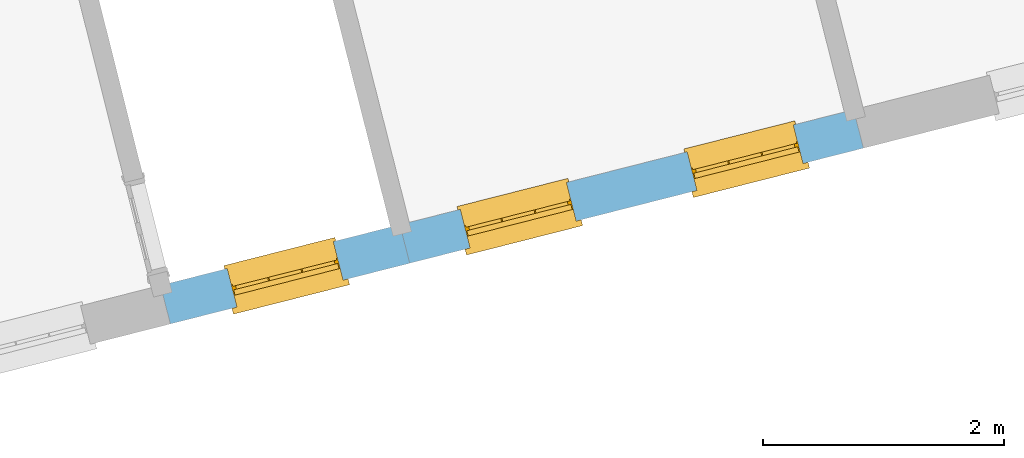
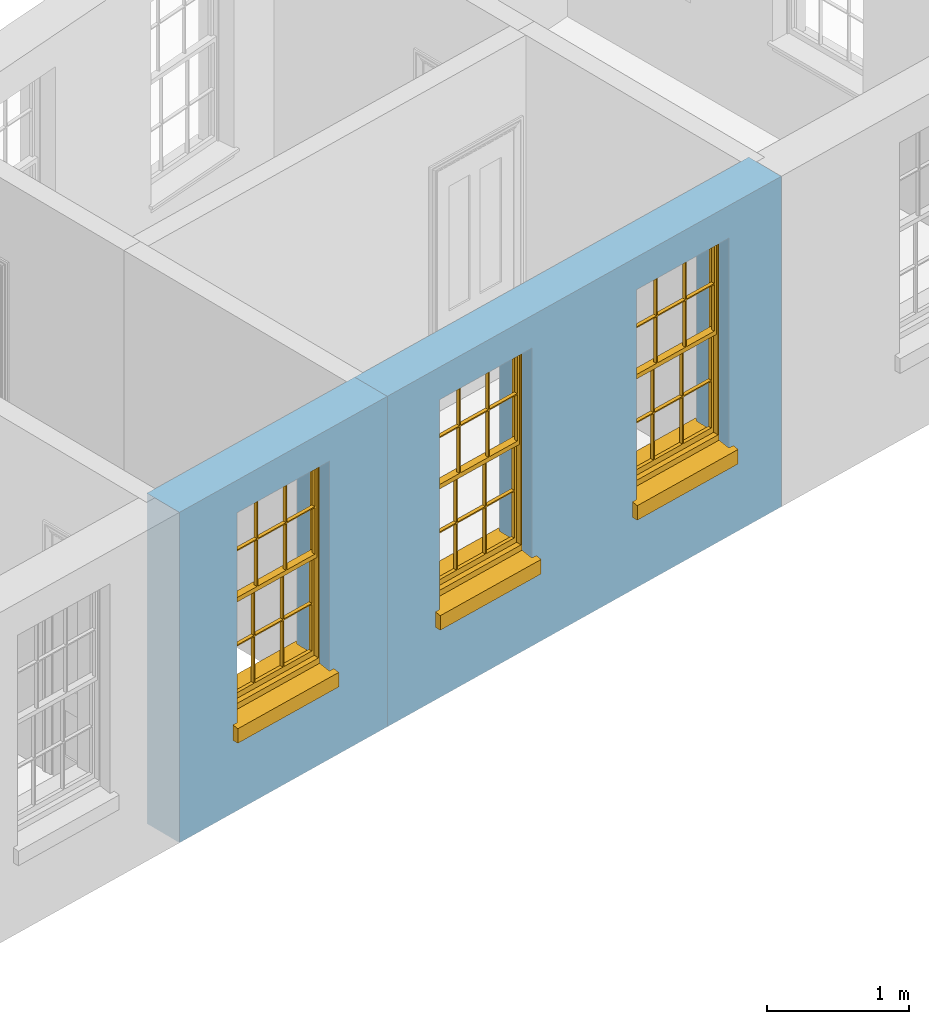
# One storey, part 5 of 11: 3 windows, 3 openings, plus 2 elements that do not belong to this part.
"""IFC2X3 building model written with IfcOpenShell, lengths in metres."""

import ifcopenshell
import ifcopenshell.guid

model = None  # the IFC model being written
_history = None  # IfcOwnerHistory: only IFC2X3 demands one
_inside = {}  # id of a spatial element -> (the spatial element, [elements in it])
_under = {}  # id of a project, library or spatial element -> (it, [spatial elements below it])
_declared = {}  # id of a project -> (the project, [libraries it declares])
_typed = {}  # id of a type object -> (the type object, [elements of that type])
_made_of = {}  # id of a material, layer set ... -> (it, [elements and type objects made of it])


def new_model(schema):
    """Start an empty IFC model of exactly this schema.

    Asked for "IFC4X3", IfcOpenShell would pick the latest addendum, in which some entities
    have other attributes; the version numbers below select the first issue.
    IFC2X3 requires an IfcOwnerHistory on every rooted entity: one is made here for all.
    """
    global model, _history
    if schema == "IFC4X3":
        model = ifcopenshell.file(schema_version=(4, 3, 0, 0))
    else:
        model = ifcopenshell.file(schema=schema)
    _inside.clear()
    _under.clear()
    _declared.clear()
    _typed.clear()
    _made_of.clear()
    _history = None
    if model.schema == "IFC2X3":
        org = make("IfcOrganization", Name="unknown")
        user = make(
            "IfcPersonAndOrganization",
            ThePerson=make("IfcPerson", FamilyName="unknown"),
            TheOrganization=org,
        )
        app = make(
            "IfcApplication",
            ApplicationDeveloper=org,
            Version="unknown",
            ApplicationFullName="unknown",
            ApplicationIdentifier="unknown",
        )
        _history = make(
            "IfcOwnerHistory",
            OwningUser=user,
            OwningApplication=app,
            ChangeAction="ADDED",
            CreationDate=0,
        )
    return model


def make(cls, **values):
    """One entity of the class cls with the attributes given. An attribute that is None is left unset."""
    return model.create_entity(
        cls, **{name: value for name, value in values.items() if value is not None}
    )


def rooted(cls, **values):
    """An entity with a GlobalId (a new one), such as an element, a storey or a relation."""
    return make(cls, GlobalId=ifcopenshell.guid.new(), OwnerHistory=_history, **values)


def si_unit(unit_type, name, prefix=None):
    """IfcSIUnit, for example si_unit("LENGTHUNIT", "METRE", prefix="MILLI")."""
    return make("IfcSIUnit", UnitType=unit_type, Prefix=prefix, Name=name)


def assignment(units):
    """IfcUnitAssignment: the units of a project."""
    return None if units is None else make("IfcUnitAssignment", Units=units)


def point(xyz):
    """IfcCartesianPoint."""
    return None if xyz is None else make("IfcCartesianPoint", Coordinates=xyz)


def direction(xyz):
    """IfcDirection."""
    return None if xyz is None else make("IfcDirection", DirectionRatios=xyz)


def frame(location, z_axis=None, x_axis=None):
    """IfcAxis2Placement3D, a coordinate frame: its origin and axes. An axis left out is left unset."""
    return make(
        "IfcAxis2Placement3D",
        Location=point(location),
        Axis=direction(z_axis),
        RefDirection=direction(x_axis),
    )


def origin():
    """The frame at (0, 0, 0) with its axes left unset."""
    return frame((0.0, 0.0, 0.0))


def place(relative_to, where):
    """IfcLocalPlacement: puts the frame where relative to a parent placement (None: the world)."""
    return make(
        "IfcLocalPlacement", PlacementRelTo=relative_to, RelativePlacement=where
    )


def context(
    kind, dimensions, precision=None, world=None, true_north=None, identifier=None
):
    """IfcGeometricRepresentationContext, for example the 3D "Model" context."""
    return make(
        "IfcGeometricRepresentationContext",
        ContextIdentifier=identifier,
        ContextType=kind,
        CoordinateSpaceDimension=dimensions,
        Precision=precision,
        WorldCoordinateSystem=world,
        TrueNorth=true_north,
    )


def subcontext(parent, identifier, kind, view, scale=None):
    """IfcGeometricRepresentationSubContext, for example "Body" below "Model"."""
    return make(
        "IfcGeometricRepresentationSubContext",
        ContextIdentifier=identifier,
        ContextType=kind,
        ParentContext=parent,
        TargetScale=scale,
        TargetView=view,
    )


def project(units=None, contexts=None):
    """IfcProject with its units and contexts."""
    return rooted(
        "IfcProject",
        Name="project",
        RepresentationContexts=contexts,
        UnitsInContext=assignment(units),
    )


def spatial(cls, under=None, at=None, **own):
    """A site, building, storey or space (cls), placed at a placement, below another one or the project."""
    s = rooted(cls, ObjectPlacement=at, **own)
    if under is not None:
        _under.setdefault(under.id(), (under, []))[1].append(s)
    return s


def polyline(points):
    """IfcPolyline through the points."""
    return make("IfcPolyline", Points=[point(p) for p in points])


def outline(outer, holes=None, kind="AREA"):
    """IfcArbitraryClosedProfileDef: a profile drawn as a closed curve; with holes, ...WithVoids."""
    if holes is None:
        return make("IfcArbitraryClosedProfileDef", ProfileType=kind, OuterCurve=outer)
    return make(
        "IfcArbitraryProfileDefWithVoids",
        ProfileType=kind,
        OuterCurve=outer,
        InnerCurves=holes,
    )


def extrude(swept, where, along, depth):
    """IfcExtrudedAreaSolid: the profile swept, set in the frame where, extruded along a direction by depth."""
    return make(
        "IfcExtrudedAreaSolid",
        SweptArea=swept,
        Position=where,
        ExtrudedDirection=direction(along),
        Depth=depth,
    )


def faces_of(points, faces, orient=None, outer=None):
    """IfcFace entities. A face is a list of loops; a loop is a list of indices into points, from 0.

    orient and outer hold one flag for each loop. By default every Orientation is true, the
    first loop of a face is its IfcFaceOuterBound and the others are IfcFaceBound.
    """
    made = []
    for i, loops in enumerate(faces):
        bounds = []
        for j, loop in enumerate(loops):
            is_outer = j == 0 if outer is None else outer[i][j]
            bounds.append(
                make(
                    "IfcFaceOuterBound" if is_outer else "IfcFaceBound",
                    Bound=make("IfcPolyLoop", Polygon=[points[k] for k in loop]),
                    Orientation=True if orient is None else orient[i][j],
                )
            )
        made.append(make("IfcFace", Bounds=bounds))
    return made


def faceted_brep(points, faces, orient=None, outer=None, voids=None):
    """IfcFacetedBrep: a solid bounded by flat faces; with voids (closed shells), ...WithVoids."""
    shared = [point(p) for p in points]
    hull = make("IfcClosedShell", CfsFaces=faces_of(shared, faces, orient, outer))
    if voids is None:
        return make("IfcFacetedBrep", Outer=hull)
    return make(
        "IfcFacetedBrepWithVoids",
        Outer=hull,
        Voids=[
            make(cls, CfsFaces=faces_of(shared, fs, o, b)) for cls, fs, o, b in voids
        ],
    )


def shape(context_of_items, identifier, shape_type, items):
    """IfcShapeRepresentation: the items that make up one representation, for example the "Body"."""
    return make(
        "IfcShapeRepresentation",
        ContextOfItems=context_of_items,
        RepresentationIdentifier=identifier,
        RepresentationType=shape_type,
        Items=items,
    )


def material(Name=None, Category=None):
    """IfcMaterial."""
    return make("IfcMaterial", Name=Name, Category=Category)


def layer(
    of_material, thickness, ventilated=None, Name=None, Category=None, Priority=None
):
    """IfcMaterialLayer: one layer of a wall or slab, of a material (None: an air gap)."""
    return make(
        "IfcMaterialLayer",
        Material=of_material,
        LayerThickness=thickness,
        IsVentilated=ventilated,
        Name=Name,
        Category=Category,
        Priority=Priority,
    )


def layer_set(layers, Name=None):
    """IfcMaterialLayerSet."""
    return make("IfcMaterialLayerSet", MaterialLayers=layers, LayerSetName=Name)


def layer_usage(for_layer_set, set_direction, sense, offset, extent=None):
    """IfcMaterialLayerSetUsage: how a layer set lies in its element."""
    return make(
        "IfcMaterialLayerSetUsage",
        ForLayerSet=for_layer_set,
        LayerSetDirection=set_direction,
        DirectionSense=sense,
        OffsetFromReferenceLine=offset,
        ReferenceExtent=extent,
    )


def made_of(thing, what):
    """Note that an element or type object is made of a material, layer set ...; save() writes the relation."""
    if what is not None:
        _made_of.setdefault(what.id(), (what, []))[1].append(thing)
    return thing


def element(
    cls,
    number,
    at=None,
    inside=None,
    cuts=None,
    type_object=None,
    material=None,
    context=None,
    identifier="Body",
    shape_type=None,
    held_by="IfcProductDefinitionShape",
    body=None,
    shapes=None,
    **own,
):
    """One element of the class cls, such as IfcWall. Its Tag is "e" and its number.

    at: its placement. inside: the storey or other place that contains it. cuts: it is an
    opening in that element (IfcRelVoidsElement). A single representation is given by context,
    identifier, shape_type and body (its items); several are given by shapes. held_by: the class
    of the entity that holds the representations. save() writes the other relations.
    """
    e = rooted(cls, Tag="e%d" % number, ObjectPlacement=at, **own)
    if body is not None:
        shapes = [shape(context, identifier, shape_type, body)]
    if shapes is not None:
        e.Representation = make(held_by, Representations=shapes)
    if inside is not None:
        _inside.setdefault(inside.id(), (inside, []))[1].append(e)
    if cuts is not None:
        rooted(
            "IfcRelVoidsElement", RelatingBuildingElement=cuts, RelatedOpeningElement=e
        )
    if type_object is not None:
        _typed.setdefault(type_object.id(), (type_object, []))[1].append(e)
    return made_of(e, material)


def fill(opening, filler):
    """IfcRelFillsElement: the door or window that sits in an opening."""
    return rooted(
        "IfcRelFillsElement",
        RelatingOpeningElement=opening,
        RelatedBuildingElement=filler,
    )


def aggregate(whole, parts):
    """IfcRelAggregates: a whole, such as a stair, and the parts it consists of."""
    return rooted("IfcRelAggregates", RelatingObject=whole, RelatedObjects=parts)


def save(model, path):
    """Write the relations noted so far, then the file.

    IfcRelAggregates (storeys below a building ...), IfcRelContainedInSpatialStructure (elements
    in a storey), IfcRelDefinesByType, IfcRelAssociatesMaterial and IfcRelDeclares: one each for
    every whole, place, type object, material and project.
    """
    for whole, parts in _under.values():
        aggregate(whole, parts)
    for where, things in _inside.values():
        rooted(
            "IfcRelContainedInSpatialStructure",
            RelatedElements=things,
            RelatingStructure=where,
        )
    for kind, things in _typed.values():
        rooted("IfcRelDefinesByType", RelatedObjects=things, RelatingType=kind)
    for what, things in _made_of.values():
        rooted("IfcRelAssociatesMaterial", RelatedObjects=things, RelatingMaterial=what)
    for by, libraries in _declared.values():
        rooted("IfcRelDeclares", RelatingContext=by, RelatedDefinitions=libraries)
    model.write(path)


model = new_model("IFC2X3")

# Units and contexts
model_context = context("Model", 3, world=origin())
body_context = subcontext(model_context, "Body", "Model", "MODEL_VIEW")
ifc_project = project(units=[si_unit("PLANEANGLEUNIT", "RADIAN"), si_unit("MASSUNIT", "GRAM", prefix="KILO"), si_unit("FORCEUNIT", "NEWTON", prefix="KILO"), si_unit("LENGTHUNIT", "METRE")], contexts=[model_context])

# Site, building, storey
site_placement = place(None, origin())
site = spatial("IfcSite", under=ifc_project, at=site_placement, CompositionType="ELEMENT")
building_placement = place(None, origin())
building = spatial("IfcBuilding", under=site, at=building_placement, Name="Building plot-13", CompositionType="ELEMENT")
storey_placement = place(None, frame((0.0, 0.0, 6.7)))
storey = spatial("IfcBuildingStorey", under=building, at=storey_placement, Name="Floor 1", CompositionType="ELEMENT", Elevation=6.7)

# Wall, opening, window
ifc_material = material(Name="Masonry")
ifc_layer = layer(ifc_material, 0.33, ventilated=False)
ifc_layer_set = layer_set([ifc_layer], Name="My Wall")
ifc_layer_usage = layer_usage(ifc_layer_set, "AXIS2", "NEGATIVE", 0.08)
wall_1_placement = place(storey_placement, origin())
wall_1 = element("IfcWallStandardCase", 1, at=wall_1_placement, inside=storey, material=ifc_layer_usage, Name="exterior", context=body_context, shape_type="SweptSolid", body=[
    extrude(outline(polyline([(71.1697724625834, 45.0137628318924), (71.2509007169492, 44.6938906600119), (73.2374229095042, 45.1977265416814), (73.1562946551384, 45.5175987135619), (71.1697724625834, 45.0137628318924)])), origin(), (0.0, 0.0, 1.0), 2.85),
])
opening_1_placement = place(storey_placement, frame((0.0, 0.0, 0.75)))
opening_1 = element("IfcOpeningElement", 2, at=opening_1_placement, cuts=wall_1, Name="Opening", ObjectType="Opening", context=body_context, shape_type="SweptSolid", body=[
    extrude(outline(polyline([(71.8031259398763, 44.8339499470999), (72.6851976865771, 45.0576672545935), (72.6040694322113, 45.377539426474), (71.7219976855105, 45.1538221189804), (71.8031259398763, 44.8339499470999)])), origin(), (0.0, 0.0, 1.0), 1.82),
])
window_1_placement = place(storey_placement, frame((71.7416651411143, 45.0762773500396, 0.75), z_axis=(0.0, 0.0, 1.0), x_axis=(0.882071746700788, 0.223717307493636, 0.0)))
window_1 = element("IfcWindow", 3, at=window_1_placement, inside=storey, Name="circulation outside window", OverallHeight=1.82, OverallWidth=0.91, context=body_context, shape_type="Brep", held_by="IfcProductRepresentation", body=[
    faceted_brep([(0.033125, -0.105, 0.975209), (0.01, -0.105, 0.975209), (0.033125, -0.105, 1.376042), (0.876875, -0.105, 0.975209), (0.876875, -0.105, 1.376042), (0.9, -0.105, 0.975209), (0.876875, -0.105, 1.386042), (0.876875, -0.105, 1.786875), (0.9, -0.105, 1.81), (0.033125, -0.105, 1.786875), (0.033125, -0.105, 1.386042), (0.01, -0.105, 1.81), (0.876875, -0.135, 1.376042), (0.876875, -0.135, 0.975209), (0.9, -0.135, 0.937083), (0.033125, -0.135, 1.786875), (0.01, -0.135, 1.81), (0.033125, -0.135, 1.386042), (0.01, -0.135, 0.937083), (0.033125, -0.135, 0.975209), (0.033125, -0.135, 1.376042), (0.876875, -0.135, 1.786875), (0.876875, -0.135, 1.386042), (0.9, -0.135, 1.81), (0.033125, -0.105, 0.937083), (0.01, -0.105, 0.937083), (0.033125, -0.105, 0.53625), (0.876875, -0.105, 0.937083), (0.876875, -0.105, 0.53625), (0.9, -0.105, 0.937083), (0.876875, -0.105, 0.52625), (0.876875, -0.105, 0.125417), (0.9, -0.105, 0.077167), (0.033125, -0.105, 0.125417), (0.033125, -0.105, 0.52625), (0.01, -0.105, 0.077167), (-0.0425, -0.25, 0.01), (-0.0425, -0.3, 0.001667), (0.0, -0.25, 0.01), (0.9525, -0.25, 0.01), (0.91, -0.25, 0.01), (0.9525, -0.3, 0.001667), (-0.02, 0.08, 0.077167), (0.0, 0.08, 0.077167), (-0.02, 0.11, 0.077167), (0.0, -0.06, 0.077167), (0.01, -0.06, 0.077167), (0.91, -0.06, 0.077167), (0.91, 0.08, 0.077167), (0.9, -0.06, 0.077167), (0.93, 0.08, 0.077167), (0.93, 0.11, 0.077167), (0.01, -0.075, 0.975209), (0.9, -0.075, 0.975209), (0.876875, -0.075, 0.125417), (0.876875, -0.075, 0.52625), (0.9, -0.075, 0.077167), (0.876875, -0.075, 0.53625), (0.876875, -0.075, 0.937083), (0.033125, -0.075, 0.125417), (0.01, -0.075, 0.077167), (0.033125, -0.075, 0.52625), (0.033125, -0.075, 0.937083), (0.033125, -0.075, 0.53625), (-0.02, 0.08, 0.052167), (-0.02, 0.11, 0.052167), (0.93, 0.11, 0.052167), (0.93, 0.08, 0.052167), (0.91, 0.08, 0.052167), (0.0, 0.08, 0.052167), (0.91, -0.15, 0.026667), (0.0, -0.15, 0.026667), (-0.0425, -0.3, -0.123333), (0.9525, -0.3, -0.123333), (-0.0425, -0.25, -0.123333), (0.9525, -0.25, -0.123333), (0.01, -0.06, 1.81), (0.9, -0.06, 1.81), (0.0, -0.06, 1.82), (0.91, -0.06, 1.82), (0.01, -0.15, 0.077167), (0.9, -0.15, 0.077167), (0.592292, -0.105, 0.125417), (0.592292, -0.075, 0.125417), (0.317708, -0.075, 0.125417), (0.317708, -0.105, 0.125417), (0.592292, -0.105, 0.53625), (0.317708, -0.105, 0.53625), (0.317708, -0.105, 0.52625), (0.592292, -0.105, 0.52625), (0.592292, -0.075, 0.53625), (0.317708, -0.075, 0.53625), (0.592292, -0.135, 1.386042), (0.592292, -0.105, 1.386042), (0.317708, -0.105, 1.386042), (0.317708, -0.135, 1.386042), (0.317708, -0.135, 1.376042), (0.592292, -0.135, 1.376042), (0.317708, -0.105, 1.376042), (0.592292, -0.105, 1.376042), (0.602292, -0.135, 1.376042), (0.592292, -0.135, 0.975209), (0.602292, -0.135, 0.975209), (0.602292, -0.105, 0.975209), (0.592292, -0.105, 0.975209), (0.602292, -0.105, 1.376042), (0.602292, -0.075, 0.53625), (0.602292, -0.105, 0.53625), (0.317708, -0.075, 0.52625), (0.307708, -0.075, 0.125417), (0.307708, -0.075, 0.52625), (0.602292, -0.075, 0.52625), (0.602292, -0.075, 0.125417), (0.592292, -0.075, 0.52625), (0.307708, -0.075, 0.53625), (0.317708, -0.075, 0.937083), (0.307708, -0.075, 0.937083), (0.602292, -0.075, 0.937083), (0.592292, -0.075, 0.937083), (0.307708, -0.105, 0.52625), (0.307708, -0.105, 0.125417), (0.307708, -0.105, 0.53625), (0.307708, -0.105, 0.937083), (0.592292, -0.105, 0.937083), (0.317708, -0.105, 0.937083), (0.602292, -0.105, 0.937083), (0.602292, -0.105, 0.52625), (0.602292, -0.105, 0.125417), (0.307708, -0.135, 1.386042), (0.307708, -0.135, 1.376042), (0.307708, -0.135, 0.975209), (0.317708, -0.135, 0.975209), (0.317708, -0.135, 1.786875), (0.307708, -0.135, 1.786875), (0.602292, -0.135, 1.786875), (0.592292, -0.135, 1.786875), (0.602292, -0.135, 1.386042), (0.602292, -0.105, 1.386042), (0.307708, -0.105, 1.386042), (0.307708, -0.105, 1.786875), (0.317708, -0.105, 1.786875), (0.592292, -0.105, 1.786875), (0.602292, -0.105, 1.786875), (0.307708, -0.105, 1.376042), (0.317708, -0.105, 0.975209), (0.307708, -0.105, 0.975209), (0.91, -0.15, 1.82), (0.9, -0.15, 1.81), (0.01, -0.15, 1.81), (0.0, -0.15, 1.82), (0.91, -0.25, 0.0), (0.0, -0.25, 0.0), (0.91, 0.08, 0.0), (0.0, 0.08, 0.0)], [[[0, 1, 2]], [[3, 4, 5]], [[6, 7, 8]], [[9, 10, 11]], [[12, 13, 14]], [[15, 16, 17]], [[18, 19, 20]], [[21, 22, 23]], [[24, 25, 26]], [[27, 28, 29]], [[30, 31, 32]], [[33, 34, 35]], [[14, 27, 29]], [[25, 24, 18]], [[36, 37, 38]], [[39, 40, 41]], [[42, 43, 44]], [[45, 46, 43]], [[47, 48, 49]], [[50, 51, 48]], [[1, 0, 52]], [[5, 53, 3]], [[54, 55, 56]], [[57, 58, 53]], [[59, 60, 61]], [[62, 63, 52]], [[48, 43, 46, 49]], [[51, 44, 43, 48]], [[64, 42, 44, 65]], [[65, 44, 51, 66]], [[66, 51, 50, 67]], [[65, 66, 68, 69]], [[60, 56, 49, 46]], [[70, 71, 38, 40]], [[37, 41, 40, 38]], [[37, 72, 73, 41]], [[74, 75, 73, 72]], [[8, 11, 76, 77]], [[76, 78, 79, 77]], [[32, 35, 80, 81]], [[81, 80, 71, 70]], [[82, 83, 84, 85]], [[86, 87, 88, 89]], [[86, 90, 91, 87]], [[92, 93, 94, 95]], [[92, 95, 96, 97]], [[96, 98, 99, 97]], [[100, 97, 101, 102]], [[103, 104, 99, 105]], [[97, 99, 104, 101]], [[102, 103, 105, 100]], [[28, 57, 106, 107]], [[108, 84, 109, 110]], [[111, 112, 83, 113]], [[114, 110, 61, 63]], [[90, 113, 108, 91]], [[115, 91, 114, 116]], [[117, 106, 90, 118]], [[111, 106, 57, 55]], [[119, 110, 109, 120]], [[34, 61, 110, 119]], [[89, 113, 83, 82]], [[88, 108, 113, 89]], [[85, 84, 108, 88]], [[121, 114, 63, 26]], [[122, 116, 114, 121]], [[123, 118, 90, 86]], [[87, 91, 115, 124]], [[107, 106, 117, 125]], [[126, 111, 55, 30]], [[127, 112, 111, 126]], [[126, 30, 28, 107]], [[88, 119, 120, 85]], [[126, 89, 82, 127]], [[125, 123, 86, 107]], [[121, 26, 34, 119]], [[124, 122, 121, 87]], [[128, 17, 20, 129]], [[96, 129, 130, 131]], [[132, 133, 128, 95]], [[134, 135, 92, 136]], [[100, 12, 22, 136]], [[137, 6, 4, 105]], [[94, 138, 139, 140]], [[137, 93, 141, 142]], [[99, 98, 94, 93]], [[143, 2, 10, 138]], [[144, 145, 143, 98]], [[129, 143, 145, 130]], [[20, 2, 143, 129]], [[131, 144, 98, 96]], [[128, 138, 10, 17]], [[133, 139, 138, 128]], [[135, 141, 93, 92]], [[95, 94, 140, 132]], [[22, 6, 137, 136]], [[136, 137, 142, 134]], [[100, 105, 4, 12]], [[107, 86, 89, 126]], [[106, 111, 113, 90]], [[91, 108, 110, 114]], [[87, 121, 119, 88]], [[97, 100, 136, 92]], [[129, 96, 95, 128]], [[98, 143, 138, 94]], [[105, 99, 93, 137]], [[131, 101, 104, 144]], [[124, 115, 118, 123]], [[132, 140, 141, 135]], [[120, 109, 59, 33]], [[15, 9, 139, 133]], [[134, 142, 7, 21]], [[31, 54, 112, 127]], [[36, 74, 72, 37]], [[39, 41, 73, 75]], [[18, 14, 101, 131]], [[23, 16, 132, 135]], [[83, 56, 60, 84]], [[52, 53, 118, 115]], [[53, 52, 144, 104]], [[11, 8, 141, 140]], [[14, 18, 124, 123]], [[2, 1, 11, 10]], [[8, 5, 4, 6]], [[57, 53, 56, 55]], [[60, 52, 63, 61]], [[26, 25, 35, 34]], [[32, 29, 28, 30]], [[14, 23, 22, 12]], [[18, 20, 17, 16]], [[19, 0, 2, 20]], [[17, 10, 9, 15]], [[12, 4, 3, 13]], [[21, 7, 6, 22]], [[27, 58, 57, 28]], [[30, 55, 54, 31]], [[33, 59, 61, 34]], [[26, 63, 62, 24]], [[5, 8, 77, 53]], [[76, 11, 1, 52]], [[46, 45, 78, 76]], [[49, 77, 79, 47]], [[70, 146, 147, 81]], [[71, 80, 148, 149]], [[19, 130, 145, 0]], [[102, 13, 3, 103]], [[116, 122, 24, 62]], [[29, 32, 81, 14]], [[80, 35, 25, 18]], [[60, 46, 76, 52]], [[77, 49, 56, 53]], [[23, 14, 81, 147]], [[16, 148, 80, 18]], [[35, 85, 120]], [[120, 33, 35]], [[127, 82, 32]], [[32, 31, 127]], [[32, 82, 85, 35]], [[102, 101, 14]], [[14, 13, 102]], [[18, 131, 130]], [[130, 19, 18]], [[134, 21, 23]], [[23, 135, 134]], [[16, 15, 133]], [[133, 132, 16]], [[11, 140, 139]], [[139, 9, 11]], [[142, 141, 8]], [[8, 7, 142]], [[23, 147, 148, 16]], [[146, 149, 148, 147]], [[52, 115, 116]], [[116, 62, 52]], [[118, 53, 117]], [[58, 117, 53]], [[27, 125, 117, 58]], [[56, 83, 112]], [[112, 54, 56]], [[109, 84, 60]], [[60, 59, 109]], [[125, 27, 14]], [[14, 123, 125]], [[122, 124, 18]], [[18, 24, 122]], [[145, 144, 52]], [[52, 0, 145]], [[103, 3, 53]], [[53, 104, 103]], [[79, 78, 149, 146]], [[78, 45, 71, 149]], [[146, 70, 47, 79]], [[150, 75, 74, 151]], [[68, 66, 67]], [[48, 68, 67, 50]], [[69, 64, 65]], [[42, 64, 69, 43]], [[69, 68, 152, 153]], [[70, 68, 48, 47]], [[150, 152, 68, 70]], [[43, 69, 71, 45]], [[69, 153, 151, 71]], [[152, 150, 151, 153]], [[38, 151, 74, 36]], [[71, 151, 38]], [[39, 75, 150, 40]], [[40, 150, 70]]]),
])
fill(opening_1, window_1)

# Wall, openings, windows
wall_2_placement = place(storey_placement, origin())
wall_2 = element("IfcWallStandardCase", 4, at=wall_2_placement, inside=storey, material=ifc_layer_usage, Name="exterior", context=body_context, shape_type="SweptSolid", body=[
    extrude(outline(polyline([(73.1562946551384, 45.5175987135619), (73.2374229095042, 45.1977265416814), (77.0032448604169, 46.1528410780099), (76.9221166060511, 46.4727132498904), (73.1562946551384, 45.5175987135619)])), origin(), (0.0, 0.0, 1.0), 2.85),
])
opening_2_placement = place(storey_placement, frame((0.0, 0.0, 0.75)))
opening_2 = element("IfcOpeningElement", 5, at=opening_2_placement, cuts=wall_2, Name="Opening", ObjectType="Opening", context=body_context, shape_type="SweptSolid", body=[
    extrude(outline(polyline([(73.737842523882, 45.3246465220167), (74.6199142705828, 45.5483638295104), (74.5387860162169, 45.8682360013909), (73.6567142695161, 45.6445186938972), (73.737842523882, 45.3246465220167)])), origin(), (0.0, 0.0, 1.0), 1.82),
])
opening_3_placement = place(storey_placement, frame((0.0, 0.0, 0.75)))
opening_3 = element("IfcOpeningElement", 6, at=opening_3_placement, cuts=wall_2, Name="Opening", ObjectType="Opening", context=body_context, shape_type="SweptSolid", body=[
    extrude(outline(polyline([(75.6207534993383, 45.802203790181), (76.5028252460391, 46.0259210976746), (76.4216969916733, 46.3457932695551), (75.5396252449725, 46.1220759620615), (75.6207534993383, 45.802203790181)])), origin(), (0.0, 0.0, 1.0), 1.82),
])
window_2_placement = place(storey_placement, frame((73.67638172512, 45.5669739249565, 0.75), z_axis=(0.0, 0.0, 1.0), x_axis=(0.882071746700802, 0.223717307493629, 0.0)))
window_2 = element("IfcWindow", 7, at=window_2_placement, inside=storey, Name="toilet outside window", OverallHeight=1.82, OverallWidth=0.91, context=body_context, shape_type="Brep", held_by="IfcProductRepresentation", body=[
    faceted_brep([(0.033125, -0.105, 0.975209), (0.01, -0.105, 0.975209), (0.033125, -0.105, 1.376042), (0.876875, -0.105, 0.975209), (0.876875, -0.105, 1.376042), (0.9, -0.105, 0.975209), (0.876875, -0.105, 1.386042), (0.876875, -0.105, 1.786875), (0.9, -0.105, 1.81), (0.033125, -0.105, 1.786875), (0.033125, -0.105, 1.386042), (0.01, -0.105, 1.81), (0.876875, -0.135, 1.376042), (0.876875, -0.135, 0.975209), (0.9, -0.135, 0.937083), (0.033125, -0.135, 1.786875), (0.01, -0.135, 1.81), (0.033125, -0.135, 1.386042), (0.01, -0.135, 0.937083), (0.033125, -0.135, 0.975209), (0.033125, -0.135, 1.376042), (0.876875, -0.135, 1.786875), (0.876875, -0.135, 1.386042), (0.9, -0.135, 1.81), (0.033125, -0.105, 0.937083), (0.01, -0.105, 0.937083), (0.033125, -0.105, 0.53625), (0.876875, -0.105, 0.937083), (0.876875, -0.105, 0.53625), (0.9, -0.105, 0.937083), (0.876875, -0.105, 0.52625), (0.876875, -0.105, 0.125417), (0.9, -0.105, 0.077167), (0.033125, -0.105, 0.125417), (0.033125, -0.105, 0.52625), (0.01, -0.105, 0.077167), (-0.0425, -0.25, 0.01), (-0.0425, -0.3, 0.001667), (0.0, -0.25, 0.01), (0.9525, -0.25, 0.01), (0.91, -0.25, 0.01), (0.9525, -0.3, 0.001667), (-0.02, 0.08, 0.077167), (0.0, 0.08, 0.077167), (-0.02, 0.11, 0.077167), (0.0, -0.06, 0.077167), (0.01, -0.06, 0.077167), (0.91, -0.06, 0.077167), (0.91, 0.08, 0.077167), (0.9, -0.06, 0.077167), (0.93, 0.08, 0.077167), (0.93, 0.11, 0.077167), (0.01, -0.075, 0.975209), (0.9, -0.075, 0.975209), (0.876875, -0.075, 0.125417), (0.876875, -0.075, 0.52625), (0.9, -0.075, 0.077167), (0.876875, -0.075, 0.53625), (0.876875, -0.075, 0.937083), (0.033125, -0.075, 0.125417), (0.01, -0.075, 0.077167), (0.033125, -0.075, 0.52625), (0.033125, -0.075, 0.937083), (0.033125, -0.075, 0.53625), (-0.02, 0.08, 0.052167), (-0.02, 0.11, 0.052167), (0.93, 0.11, 0.052167), (0.93, 0.08, 0.052167), (0.91, 0.08, 0.052167), (0.0, 0.08, 0.052167), (0.91, -0.15, 0.026667), (0.0, -0.15, 0.026667), (-0.0425, -0.3, -0.123333), (0.9525, -0.3, -0.123333), (-0.0425, -0.25, -0.123333), (0.9525, -0.25, -0.123333), (0.01, -0.06, 1.81), (0.9, -0.06, 1.81), (0.0, -0.06, 1.82), (0.91, -0.06, 1.82), (0.01, -0.15, 0.077167), (0.9, -0.15, 0.077167), (0.592292, -0.105, 0.125417), (0.592292, -0.075, 0.125417), (0.317708, -0.075, 0.125417), (0.317708, -0.105, 0.125417), (0.592292, -0.105, 0.53625), (0.317708, -0.105, 0.53625), (0.317708, -0.105, 0.52625), (0.592292, -0.105, 0.52625), (0.592292, -0.075, 0.53625), (0.317708, -0.075, 0.53625), (0.592292, -0.135, 1.386042), (0.592292, -0.105, 1.386042), (0.317708, -0.105, 1.386042), (0.317708, -0.135, 1.386042), (0.317708, -0.135, 1.376042), (0.592292, -0.135, 1.376042), (0.317708, -0.105, 1.376042), (0.592292, -0.105, 1.376042), (0.602292, -0.135, 1.376042), (0.592292, -0.135, 0.975209), (0.602292, -0.135, 0.975209), (0.602292, -0.105, 0.975209), (0.592292, -0.105, 0.975209), (0.602292, -0.105, 1.376042), (0.602292, -0.075, 0.53625), (0.602292, -0.105, 0.53625), (0.317708, -0.075, 0.52625), (0.307708, -0.075, 0.125417), (0.307708, -0.075, 0.52625), (0.602292, -0.075, 0.52625), (0.602292, -0.075, 0.125417), (0.592292, -0.075, 0.52625), (0.307708, -0.075, 0.53625), (0.317708, -0.075, 0.937083), (0.307708, -0.075, 0.937083), (0.602292, -0.075, 0.937083), (0.592292, -0.075, 0.937083), (0.307708, -0.105, 0.52625), (0.307708, -0.105, 0.125417), (0.307708, -0.105, 0.53625), (0.307708, -0.105, 0.937083), (0.592292, -0.105, 0.937083), (0.317708, -0.105, 0.937083), (0.602292, -0.105, 0.937083), (0.602292, -0.105, 0.52625), (0.602292, -0.105, 0.125417), (0.307708, -0.135, 1.386042), (0.307708, -0.135, 1.376042), (0.307708, -0.135, 0.975209), (0.317708, -0.135, 0.975209), (0.317708, -0.135, 1.786875), (0.307708, -0.135, 1.786875), (0.602292, -0.135, 1.786875), (0.592292, -0.135, 1.786875), (0.602292, -0.135, 1.386042), (0.602292, -0.105, 1.386042), (0.307708, -0.105, 1.386042), (0.307708, -0.105, 1.786875), (0.317708, -0.105, 1.786875), (0.592292, -0.105, 1.786875), (0.602292, -0.105, 1.786875), (0.307708, -0.105, 1.376042), (0.317708, -0.105, 0.975209), (0.307708, -0.105, 0.975209), (0.91, -0.15, 1.82), (0.9, -0.15, 1.81), (0.01, -0.15, 1.81), (0.0, -0.15, 1.82), (0.91, -0.25, 0.0), (0.0, -0.25, 0.0), (0.91, 0.08, 0.0), (0.0, 0.08, 0.0)], [[[0, 1, 2]], [[3, 4, 5]], [[6, 7, 8]], [[9, 10, 11]], [[12, 13, 14]], [[15, 16, 17]], [[18, 19, 20]], [[21, 22, 23]], [[24, 25, 26]], [[27, 28, 29]], [[30, 31, 32]], [[33, 34, 35]], [[14, 27, 29]], [[25, 24, 18]], [[36, 37, 38]], [[39, 40, 41]], [[42, 43, 44]], [[45, 46, 43]], [[47, 48, 49]], [[50, 51, 48]], [[1, 0, 52]], [[5, 53, 3]], [[54, 55, 56]], [[57, 58, 53]], [[59, 60, 61]], [[62, 63, 52]], [[48, 43, 46, 49]], [[51, 44, 43, 48]], [[64, 42, 44, 65]], [[65, 44, 51, 66]], [[66, 51, 50, 67]], [[65, 66, 68, 69]], [[60, 56, 49, 46]], [[70, 71, 38, 40]], [[37, 41, 40, 38]], [[37, 72, 73, 41]], [[74, 75, 73, 72]], [[8, 11, 76, 77]], [[76, 78, 79, 77]], [[32, 35, 80, 81]], [[81, 80, 71, 70]], [[82, 83, 84, 85]], [[86, 87, 88, 89]], [[86, 90, 91, 87]], [[92, 93, 94, 95]], [[92, 95, 96, 97]], [[96, 98, 99, 97]], [[100, 97, 101, 102]], [[103, 104, 99, 105]], [[97, 99, 104, 101]], [[102, 103, 105, 100]], [[28, 57, 106, 107]], [[108, 84, 109, 110]], [[111, 112, 83, 113]], [[114, 110, 61, 63]], [[90, 113, 108, 91]], [[115, 91, 114, 116]], [[117, 106, 90, 118]], [[111, 106, 57, 55]], [[119, 110, 109, 120]], [[34, 61, 110, 119]], [[89, 113, 83, 82]], [[88, 108, 113, 89]], [[85, 84, 108, 88]], [[121, 114, 63, 26]], [[122, 116, 114, 121]], [[123, 118, 90, 86]], [[87, 91, 115, 124]], [[107, 106, 117, 125]], [[126, 111, 55, 30]], [[127, 112, 111, 126]], [[126, 30, 28, 107]], [[88, 119, 120, 85]], [[126, 89, 82, 127]], [[125, 123, 86, 107]], [[121, 26, 34, 119]], [[124, 122, 121, 87]], [[128, 17, 20, 129]], [[96, 129, 130, 131]], [[132, 133, 128, 95]], [[134, 135, 92, 136]], [[100, 12, 22, 136]], [[137, 6, 4, 105]], [[94, 138, 139, 140]], [[137, 93, 141, 142]], [[99, 98, 94, 93]], [[143, 2, 10, 138]], [[144, 145, 143, 98]], [[129, 143, 145, 130]], [[20, 2, 143, 129]], [[131, 144, 98, 96]], [[128, 138, 10, 17]], [[133, 139, 138, 128]], [[135, 141, 93, 92]], [[95, 94, 140, 132]], [[22, 6, 137, 136]], [[136, 137, 142, 134]], [[100, 105, 4, 12]], [[107, 86, 89, 126]], [[106, 111, 113, 90]], [[91, 108, 110, 114]], [[87, 121, 119, 88]], [[97, 100, 136, 92]], [[129, 96, 95, 128]], [[98, 143, 138, 94]], [[105, 99, 93, 137]], [[131, 101, 104, 144]], [[124, 115, 118, 123]], [[132, 140, 141, 135]], [[120, 109, 59, 33]], [[15, 9, 139, 133]], [[134, 142, 7, 21]], [[31, 54, 112, 127]], [[36, 74, 72, 37]], [[39, 41, 73, 75]], [[18, 14, 101, 131]], [[23, 16, 132, 135]], [[83, 56, 60, 84]], [[52, 53, 118, 115]], [[53, 52, 144, 104]], [[11, 8, 141, 140]], [[14, 18, 124, 123]], [[2, 1, 11, 10]], [[8, 5, 4, 6]], [[57, 53, 56, 55]], [[60, 52, 63, 61]], [[26, 25, 35, 34]], [[32, 29, 28, 30]], [[14, 23, 22, 12]], [[18, 20, 17, 16]], [[19, 0, 2, 20]], [[17, 10, 9, 15]], [[12, 4, 3, 13]], [[21, 7, 6, 22]], [[27, 58, 57, 28]], [[30, 55, 54, 31]], [[33, 59, 61, 34]], [[26, 63, 62, 24]], [[5, 8, 77, 53]], [[76, 11, 1, 52]], [[46, 45, 78, 76]], [[49, 77, 79, 47]], [[70, 146, 147, 81]], [[71, 80, 148, 149]], [[19, 130, 145, 0]], [[102, 13, 3, 103]], [[116, 122, 24, 62]], [[29, 32, 81, 14]], [[80, 35, 25, 18]], [[60, 46, 76, 52]], [[77, 49, 56, 53]], [[23, 14, 81, 147]], [[16, 148, 80, 18]], [[35, 85, 120]], [[120, 33, 35]], [[127, 82, 32]], [[32, 31, 127]], [[32, 82, 85, 35]], [[102, 101, 14]], [[14, 13, 102]], [[18, 131, 130]], [[130, 19, 18]], [[134, 21, 23]], [[23, 135, 134]], [[16, 15, 133]], [[133, 132, 16]], [[11, 140, 139]], [[139, 9, 11]], [[142, 141, 8]], [[8, 7, 142]], [[23, 147, 148, 16]], [[146, 149, 148, 147]], [[52, 115, 116]], [[116, 62, 52]], [[118, 53, 117]], [[58, 117, 53]], [[27, 125, 117, 58]], [[56, 83, 112]], [[112, 54, 56]], [[109, 84, 60]], [[60, 59, 109]], [[125, 27, 14]], [[14, 123, 125]], [[122, 124, 18]], [[18, 24, 122]], [[145, 144, 52]], [[52, 0, 145]], [[103, 3, 53]], [[53, 104, 103]], [[79, 78, 149, 146]], [[78, 45, 71, 149]], [[146, 70, 47, 79]], [[150, 75, 74, 151]], [[68, 66, 67]], [[48, 68, 67, 50]], [[69, 64, 65]], [[42, 64, 69, 43]], [[69, 68, 152, 153]], [[70, 68, 48, 47]], [[150, 152, 68, 70]], [[43, 69, 71, 45]], [[69, 153, 151, 71]], [[152, 150, 151, 153]], [[38, 151, 74, 36]], [[71, 151, 38]], [[39, 75, 150, 40]], [[40, 150, 70]]]),
])
fill(opening_2, window_2)
window_3_placement = place(storey_placement, frame((75.5592927005763, 46.0445311931208, 0.75), z_axis=(0.0, 0.0, 1.0), x_axis=(0.882071746700802, 0.223717307493629, 0.0)))
window_3 = element("IfcWindow", 8, at=window_3_placement, inside=storey, Name="toilet outside window", OverallHeight=1.82, OverallWidth=0.91, context=body_context, shape_type="Brep", held_by="IfcProductRepresentation", body=[
    faceted_brep([(0.033125, -0.105, 0.975209), (0.01, -0.105, 0.975209), (0.033125, -0.105, 1.376042), (0.876875, -0.105, 0.975209), (0.876875, -0.105, 1.376042), (0.9, -0.105, 0.975209), (0.876875, -0.105, 1.386042), (0.876875, -0.105, 1.786875), (0.9, -0.105, 1.81), (0.033125, -0.105, 1.786875), (0.033125, -0.105, 1.386042), (0.01, -0.105, 1.81), (0.876875, -0.135, 1.376042), (0.876875, -0.135, 0.975209), (0.9, -0.135, 0.937083), (0.033125, -0.135, 1.786875), (0.01, -0.135, 1.81), (0.033125, -0.135, 1.386042), (0.01, -0.135, 0.937083), (0.033125, -0.135, 0.975209), (0.033125, -0.135, 1.376042), (0.876875, -0.135, 1.786875), (0.876875, -0.135, 1.386042), (0.9, -0.135, 1.81), (0.033125, -0.105, 0.937083), (0.01, -0.105, 0.937083), (0.033125, -0.105, 0.53625), (0.876875, -0.105, 0.937083), (0.876875, -0.105, 0.53625), (0.9, -0.105, 0.937083), (0.876875, -0.105, 0.52625), (0.876875, -0.105, 0.125417), (0.9, -0.105, 0.077167), (0.033125, -0.105, 0.125417), (0.033125, -0.105, 0.52625), (0.01, -0.105, 0.077167), (-0.0425, -0.25, 0.01), (-0.0425, -0.3, 0.001667), (0.0, -0.25, 0.01), (0.9525, -0.25, 0.01), (0.91, -0.25, 0.01), (0.9525, -0.3, 0.001667), (-0.02, 0.08, 0.077167), (0.0, 0.08, 0.077167), (-0.02, 0.11, 0.077167), (0.0, -0.06, 0.077167), (0.01, -0.06, 0.077167), (0.91, -0.06, 0.077167), (0.91, 0.08, 0.077167), (0.9, -0.06, 0.077167), (0.93, 0.08, 0.077167), (0.93, 0.11, 0.077167), (0.01, -0.075, 0.975209), (0.9, -0.075, 0.975209), (0.876875, -0.075, 0.125417), (0.876875, -0.075, 0.52625), (0.9, -0.075, 0.077167), (0.876875, -0.075, 0.53625), (0.876875, -0.075, 0.937083), (0.033125, -0.075, 0.125417), (0.01, -0.075, 0.077167), (0.033125, -0.075, 0.52625), (0.033125, -0.075, 0.937083), (0.033125, -0.075, 0.53625), (-0.02, 0.08, 0.052167), (-0.02, 0.11, 0.052167), (0.93, 0.11, 0.052167), (0.93, 0.08, 0.052167), (0.91, 0.08, 0.052167), (0.0, 0.08, 0.052167), (0.91, -0.15, 0.026667), (0.0, -0.15, 0.026667), (-0.0425, -0.3, -0.123333), (0.9525, -0.3, -0.123333), (-0.0425, -0.25, -0.123333), (0.9525, -0.25, -0.123333), (0.01, -0.06, 1.81), (0.9, -0.06, 1.81), (0.0, -0.06, 1.82), (0.91, -0.06, 1.82), (0.01, -0.15, 0.077167), (0.9, -0.15, 0.077167), (0.592292, -0.105, 0.125417), (0.592292, -0.075, 0.125417), (0.317708, -0.075, 0.125417), (0.317708, -0.105, 0.125417), (0.592292, -0.105, 0.53625), (0.317708, -0.105, 0.53625), (0.317708, -0.105, 0.52625), (0.592292, -0.105, 0.52625), (0.592292, -0.075, 0.53625), (0.317708, -0.075, 0.53625), (0.592292, -0.135, 1.386042), (0.592292, -0.105, 1.386042), (0.317708, -0.105, 1.386042), (0.317708, -0.135, 1.386042), (0.317708, -0.135, 1.376042), (0.592292, -0.135, 1.376042), (0.317708, -0.105, 1.376042), (0.592292, -0.105, 1.376042), (0.602292, -0.135, 1.376042), (0.592292, -0.135, 0.975209), (0.602292, -0.135, 0.975209), (0.602292, -0.105, 0.975209), (0.592292, -0.105, 0.975209), (0.602292, -0.105, 1.376042), (0.602292, -0.075, 0.53625), (0.602292, -0.105, 0.53625), (0.317708, -0.075, 0.52625), (0.307708, -0.075, 0.125417), (0.307708, -0.075, 0.52625), (0.602292, -0.075, 0.52625), (0.602292, -0.075, 0.125417), (0.592292, -0.075, 0.52625), (0.307708, -0.075, 0.53625), (0.317708, -0.075, 0.937083), (0.307708, -0.075, 0.937083), (0.602292, -0.075, 0.937083), (0.592292, -0.075, 0.937083), (0.307708, -0.105, 0.52625), (0.307708, -0.105, 0.125417), (0.307708, -0.105, 0.53625), (0.307708, -0.105, 0.937083), (0.592292, -0.105, 0.937083), (0.317708, -0.105, 0.937083), (0.602292, -0.105, 0.937083), (0.602292, -0.105, 0.52625), (0.602292, -0.105, 0.125417), (0.307708, -0.135, 1.386042), (0.307708, -0.135, 1.376042), (0.307708, -0.135, 0.975209), (0.317708, -0.135, 0.975209), (0.317708, -0.135, 1.786875), (0.307708, -0.135, 1.786875), (0.602292, -0.135, 1.786875), (0.592292, -0.135, 1.786875), (0.602292, -0.135, 1.386042), (0.602292, -0.105, 1.386042), (0.307708, -0.105, 1.386042), (0.307708, -0.105, 1.786875), (0.317708, -0.105, 1.786875), (0.592292, -0.105, 1.786875), (0.602292, -0.105, 1.786875), (0.307708, -0.105, 1.376042), (0.317708, -0.105, 0.975209), (0.307708, -0.105, 0.975209), (0.91, -0.15, 1.82), (0.9, -0.15, 1.81), (0.01, -0.15, 1.81), (0.0, -0.15, 1.82), (0.91, -0.25, 0.0), (0.0, -0.25, 0.0), (0.91, 0.08, 0.0), (0.0, 0.08, 0.0)], [[[0, 1, 2]], [[3, 4, 5]], [[6, 7, 8]], [[9, 10, 11]], [[12, 13, 14]], [[15, 16, 17]], [[18, 19, 20]], [[21, 22, 23]], [[24, 25, 26]], [[27, 28, 29]], [[30, 31, 32]], [[33, 34, 35]], [[14, 27, 29]], [[25, 24, 18]], [[36, 37, 38]], [[39, 40, 41]], [[42, 43, 44]], [[45, 46, 43]], [[47, 48, 49]], [[50, 51, 48]], [[1, 0, 52]], [[5, 53, 3]], [[54, 55, 56]], [[57, 58, 53]], [[59, 60, 61]], [[62, 63, 52]], [[48, 43, 46, 49]], [[51, 44, 43, 48]], [[64, 42, 44, 65]], [[65, 44, 51, 66]], [[66, 51, 50, 67]], [[65, 66, 68, 69]], [[60, 56, 49, 46]], [[70, 71, 38, 40]], [[37, 41, 40, 38]], [[37, 72, 73, 41]], [[74, 75, 73, 72]], [[8, 11, 76, 77]], [[76, 78, 79, 77]], [[32, 35, 80, 81]], [[81, 80, 71, 70]], [[82, 83, 84, 85]], [[86, 87, 88, 89]], [[86, 90, 91, 87]], [[92, 93, 94, 95]], [[92, 95, 96, 97]], [[96, 98, 99, 97]], [[100, 97, 101, 102]], [[103, 104, 99, 105]], [[97, 99, 104, 101]], [[102, 103, 105, 100]], [[28, 57, 106, 107]], [[108, 84, 109, 110]], [[111, 112, 83, 113]], [[114, 110, 61, 63]], [[90, 113, 108, 91]], [[115, 91, 114, 116]], [[117, 106, 90, 118]], [[111, 106, 57, 55]], [[119, 110, 109, 120]], [[34, 61, 110, 119]], [[89, 113, 83, 82]], [[88, 108, 113, 89]], [[85, 84, 108, 88]], [[121, 114, 63, 26]], [[122, 116, 114, 121]], [[123, 118, 90, 86]], [[87, 91, 115, 124]], [[107, 106, 117, 125]], [[126, 111, 55, 30]], [[127, 112, 111, 126]], [[126, 30, 28, 107]], [[88, 119, 120, 85]], [[126, 89, 82, 127]], [[125, 123, 86, 107]], [[121, 26, 34, 119]], [[124, 122, 121, 87]], [[128, 17, 20, 129]], [[96, 129, 130, 131]], [[132, 133, 128, 95]], [[134, 135, 92, 136]], [[100, 12, 22, 136]], [[137, 6, 4, 105]], [[94, 138, 139, 140]], [[137, 93, 141, 142]], [[99, 98, 94, 93]], [[143, 2, 10, 138]], [[144, 145, 143, 98]], [[129, 143, 145, 130]], [[20, 2, 143, 129]], [[131, 144, 98, 96]], [[128, 138, 10, 17]], [[133, 139, 138, 128]], [[135, 141, 93, 92]], [[95, 94, 140, 132]], [[22, 6, 137, 136]], [[136, 137, 142, 134]], [[100, 105, 4, 12]], [[107, 86, 89, 126]], [[106, 111, 113, 90]], [[91, 108, 110, 114]], [[87, 121, 119, 88]], [[97, 100, 136, 92]], [[129, 96, 95, 128]], [[98, 143, 138, 94]], [[105, 99, 93, 137]], [[131, 101, 104, 144]], [[124, 115, 118, 123]], [[132, 140, 141, 135]], [[120, 109, 59, 33]], [[15, 9, 139, 133]], [[134, 142, 7, 21]], [[31, 54, 112, 127]], [[36, 74, 72, 37]], [[39, 41, 73, 75]], [[18, 14, 101, 131]], [[23, 16, 132, 135]], [[83, 56, 60, 84]], [[52, 53, 118, 115]], [[53, 52, 144, 104]], [[11, 8, 141, 140]], [[14, 18, 124, 123]], [[2, 1, 11, 10]], [[8, 5, 4, 6]], [[57, 53, 56, 55]], [[60, 52, 63, 61]], [[26, 25, 35, 34]], [[32, 29, 28, 30]], [[14, 23, 22, 12]], [[18, 20, 17, 16]], [[19, 0, 2, 20]], [[17, 10, 9, 15]], [[12, 4, 3, 13]], [[21, 7, 6, 22]], [[27, 58, 57, 28]], [[30, 55, 54, 31]], [[33, 59, 61, 34]], [[26, 63, 62, 24]], [[5, 8, 77, 53]], [[76, 11, 1, 52]], [[46, 45, 78, 76]], [[49, 77, 79, 47]], [[70, 146, 147, 81]], [[71, 80, 148, 149]], [[19, 130, 145, 0]], [[102, 13, 3, 103]], [[116, 122, 24, 62]], [[29, 32, 81, 14]], [[80, 35, 25, 18]], [[60, 46, 76, 52]], [[77, 49, 56, 53]], [[23, 14, 81, 147]], [[16, 148, 80, 18]], [[35, 85, 120]], [[120, 33, 35]], [[127, 82, 32]], [[32, 31, 127]], [[32, 82, 85, 35]], [[102, 101, 14]], [[14, 13, 102]], [[18, 131, 130]], [[130, 19, 18]], [[134, 21, 23]], [[23, 135, 134]], [[16, 15, 133]], [[133, 132, 16]], [[11, 140, 139]], [[139, 9, 11]], [[142, 141, 8]], [[8, 7, 142]], [[23, 147, 148, 16]], [[146, 149, 148, 147]], [[52, 115, 116]], [[116, 62, 52]], [[118, 53, 117]], [[58, 117, 53]], [[27, 125, 117, 58]], [[56, 83, 112]], [[112, 54, 56]], [[109, 84, 60]], [[60, 59, 109]], [[125, 27, 14]], [[14, 123, 125]], [[122, 124, 18]], [[18, 24, 122]], [[145, 144, 52]], [[52, 0, 145]], [[103, 3, 53]], [[53, 104, 103]], [[79, 78, 149, 146]], [[78, 45, 71, 149]], [[146, 70, 47, 79]], [[150, 75, 74, 151]], [[68, 66, 67]], [[48, 68, 67, 50]], [[69, 64, 65]], [[42, 64, 69, 43]], [[69, 68, 152, 153]], [[70, 68, 48, 47]], [[150, 152, 68, 70]], [[43, 69, 71, 45]], [[69, 153, 151, 71]], [[152, 150, 151, 153]], [[38, 151, 74, 36]], [[71, 151, 38]], [[39, 75, 150, 40]], [[40, 150, 70]]]),
])
fill(opening_3, window_3)

save(model, "model.ifc")
